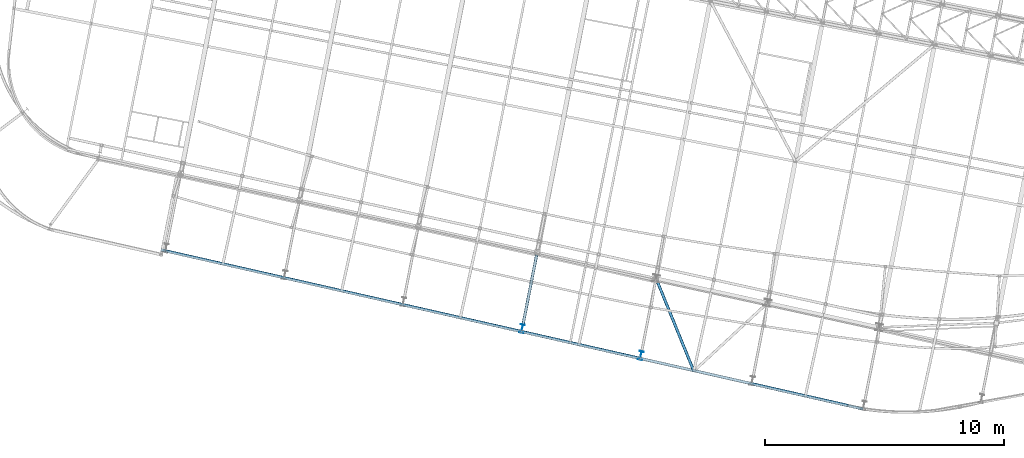
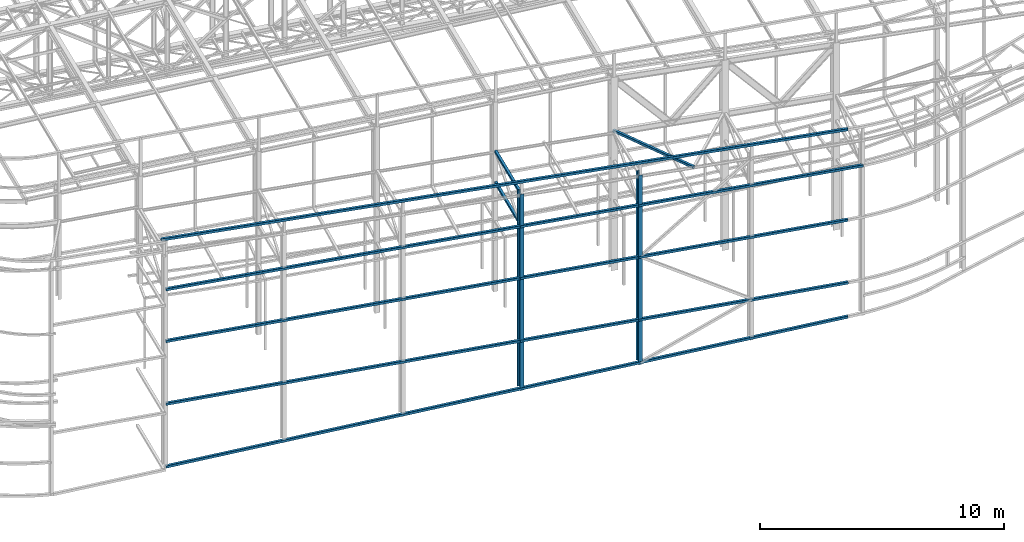
# One storey, part 27 of 215: 10 beams, 10 elements without a shape of their own.
"""IFC2X3 building model written with IfcOpenShell, lengths in millimetres."""

from ifc_helpers import new_model, si_unit, frame, origin_with_axes, origin_2d_with_axis, place, context, subcontext, project, spatial, hollow_rectangle, i_section, extrude, clip, halfspace, material, type_object, element, aggregate, save


model = new_model("IFC2X3")

# Units and contexts
model_context = context("Model", 3, precision=1e-05, world=origin_with_axes())
body_context = subcontext(model_context, "Body", "Model", "MODEL_VIEW")
ifc_project = project(units=[si_unit("LENGTHUNIT", "METRE", prefix="MILLI"), si_unit("AREAUNIT", "SQUARE_METRE"), si_unit("VOLUMEUNIT", "CUBIC_METRE"), si_unit("MASSUNIT", "GRAM", prefix="KILO"), si_unit("TIMEUNIT", "SECOND"), si_unit("PLANEANGLEUNIT", "RADIAN"), si_unit("SOLIDANGLEUNIT", "STERADIAN"), si_unit("THERMODYNAMICTEMPERATUREUNIT", "DEGREE_CELSIUS"), si_unit("LUMINOUSINTENSITYUNIT", "LUMEN")], contexts=[model_context])

# Site, building, storey
site_placement = place(None, origin_with_axes())
site = spatial("IfcSite", under=ifc_project, at=site_placement, CompositionType="ELEMENT")
building_placement = place(site_placement, origin_with_axes())
building = spatial("IfcBuilding", under=site, at=building_placement, Name="Undefined", CompositionType="ELEMENT")
storey_placement = place(building_placement, origin_with_axes())
storey = spatial("IfcBuildingStorey", under=building, at=storey_placement, Name="Undefined", CompositionType="ELEMENT", Elevation=0.0)

# Assembly, beam
assembly_1_placement = place(storey_placement, origin_with_axes())
assembly_1 = element("IfcElementAssembly", 1, at=assembly_1_placement, inside=storey, Name="Steel Assembly", AssemblyPlace="NOTDEFINED", PredefinedType="RIGID_FRAME")
ifc_material = material(Name="STEEL/S275JR")
beam_type_1 = type_object("IfcBeamType", PredefinedType="NOTDEFINED")
beam_1_placement = place(assembly_1_placement, frame((72949.1255548066, 509.827935139979, 10650.1393730401), z_axis=(0.0194175550049472, -0.00439917700112107, 0.999801783254732), x_axis=(-0.975090257036371, 0.22091309700824, 0.0199096510007426)))
beam_1 = element("IfcBeam", 2, at=beam_1_placement, type_object=beam_type_1, material=ifc_material, Name="LISSE", context=body_context, shape_type="SweptSolid", body=[
    extrude(hollow_rectangle(XDim=120.0, YDim=120.0, WallThickness=4.0, InnerFilletRadius=4.0, OuterFilletRadius=8.0, at=origin_2d_with_axis()), frame((29461.0560149092, 3.76084683702483e-12, 1.81898940354586e-12), z_axis=(-1.0, 0.0, 0.0), x_axis=(-6.93889390390723e-18, -1.0, -3.46944695195361e-18)), (0.0, 0.0, 1.0), 29461.1),
])
aggregate(assembly_1, [beam_1])

assembly_2_placement = place(storey_placement, origin_with_axes())
assembly_2 = element("IfcElementAssembly", 3, at=assembly_2_placement, inside=storey, Name="Steel Assembly", AssemblyPlace="NOTDEFINED", PredefinedType="RIGID_FRAME")
beam_type_2 = type_object("IfcBeamType", PredefinedType="NOTDEFINED")
beam_2_placement = place(assembly_2_placement, frame((44418.1952384561, 6974.22611067244, 2980.9622244853), z_axis=(0.220975588983775, 0.975279338928384, -1.1518999999289e-05), x_axis=(0.975279338993088, -0.220975588998434, 0.0)))
beam_2 = element("IfcBeam", 4, at=beam_2_placement, type_object=beam_type_2, material=ifc_material, Name="LISSE", context=body_context, shape_type="SweptSolid", body=[
    extrude(hollow_rectangle(XDim=120.0, YDim=120.0, WallThickness=5.0, InnerFilletRadius=5.0, OuterFilletRadius=10.0, at=origin_2d_with_axis()), frame((29258.826416603, 4.54759742481451e-13, 3.63797880709171e-12), z_axis=(-1.0, 0.0, 0.0), x_axis=(-6.93889390390723e-18, -1.0, -3.46944695195361e-18)), (0.0, 0.0, 1.0), 29258.8),
])
aggregate(assembly_2, [beam_2])

assembly_3_placement = place(storey_placement, origin_with_axes())
assembly_3 = element("IfcElementAssembly", 5, at=assembly_3_placement, inside=storey, Name="Steel Assembly", AssemblyPlace="NOTDEFINED", PredefinedType="RIGID_FRAME")
beam_3_placement = place(assembly_3_placement, frame((44416.3985886134, 6974.67105643174, -155.670493262422), z_axis=(0.221097669099213, 0.975251670437612, -5.24800000234946e-06), x_axis=(0.974081564682385, -0.220832132927994, 0.0489721799840319)))
beam_3 = element("IfcBeam", 6, at=beam_3_placement, type_object=beam_type_2, material=ifc_material, Name="LISSE", context=body_context, shape_type="SweptSolid", body=[
    extrude(hollow_rectangle(XDim=120.0, YDim=120.0, WallThickness=5.0, InnerFilletRadius=5.0, OuterFilletRadius=10.0, at=origin_2d_with_axis()), frame((29289.8930820894, -2.03239460553405e-13, 4.06836788812386e-12), z_axis=(-1.0, 0.0, 0.0), x_axis=(-6.93889390390723e-18, -1.0, -3.46944695195361e-18)), (0.0, 0.0, 1.0), 29289.9),
])
aggregate(assembly_3, [beam_3])

assembly_4_placement = place(storey_placement, origin_with_axes())
assembly_4 = element("IfcElementAssembly", 7, at=assembly_4_placement, inside=storey, Name="Steel Assembly", AssemblyPlace="NOTDEFINED", PredefinedType="RIGID_FRAME")
beam_4_placement = place(assembly_4_placement, frame((44414.7050663599, 6975.05394820363, 8706.00054876969), z_axis=(0.220975588983775, 0.975279338928384, -1.1518999999289e-05), x_axis=(0.975279338993088, -0.220975588998434, 0.0)))
beam_4 = element("IfcBeam", 8, at=beam_4_placement, type_object=beam_type_2, material=ifc_material, Name="LISSE", context=body_context, shape_type="SweptSolid", body=[
    extrude(hollow_rectangle(XDim=120.0, YDim=120.0, WallThickness=5.0, InnerFilletRadius=5.0, OuterFilletRadius=10.0, at=origin_2d_with_axis()), frame((29913.2202389001, 3.63797880709171e-12, 0.0), z_axis=(-1.0, 0.0, 0.0), x_axis=(-6.93889390390723e-18, -1.0, -3.46944695195361e-18)), (0.0, 0.0, 1.0), 29913.2),
])
aggregate(assembly_4, [beam_4])

assembly_5_placement = place(storey_placement, origin_with_axes())
assembly_5 = element("IfcElementAssembly", 9, at=assembly_5_placement, inside=storey, Name="Steel Assembly", AssemblyPlace="NOTDEFINED", PredefinedType="RIGID_FRAME")
beam_5_placement = place(assembly_5_placement, frame((44414.7321978085, 6975.04780065037, 6117.50421482941), z_axis=(0.220975588983775, 0.975279338928384, -1.1518999999289e-05), x_axis=(0.975279338993088, -0.220975588998434, 0.0)))
beam_5 = element("IfcBeam", 10, at=beam_5_placement, type_object=beam_type_2, material=ifc_material, Name="LISSE", context=body_context, shape_type="SweptSolid", body=[
    extrude(hollow_rectangle(XDim=120.0, YDim=120.0, WallThickness=5.0, InnerFilletRadius=5.0, OuterFilletRadius=10.0, at=origin_2d_with_axis()), frame((29258.826416603, 4.54759742481451e-13, 3.63797880709171e-12), z_axis=(-1.0, 0.0, 0.0), x_axis=(-6.93889390390723e-18, -1.0, -3.46944695195361e-18)), (0.0, 0.0, 1.0), 29258.8),
])
aggregate(assembly_5, [beam_5])

assembly_6_placement = place(storey_placement, origin_with_axes())
assembly_6 = element("IfcElementAssembly", 11, at=assembly_6_placement, inside=storey, Name="Steel Assembly", AssemblyPlace="NOTDEFINED", PredefinedType="RIGID_FRAME")
beam_6_placement = place(assembly_6_placement, frame((59367.0999275982, 3897.55622107733, 10272.058803346), z_axis=(-0.981422412140383, 0.191859451027444, 0.0), x_axis=(0.191859470081235, 0.981422408415534, 0.0)))
beam_6 = element("IfcBeam", 12, at=beam_6_placement, type_object=beam_type_2, material=ifc_material, context=body_context, shape_type="SweptSolid", body=[
    extrude(hollow_rectangle(XDim=120.0, YDim=120.0, WallThickness=5.0, InnerFilletRadius=5.0, OuterFilletRadius=10.0, at=origin_2d_with_axis()), frame((2966.85565612287, 1.81898940293233e-12, 8.23467865041747e-14), z_axis=(-1.0, 0.0, 0.0), x_axis=(-6.93889390390723e-18, -1.0, -3.46944695195361e-18)), (0.0, 0.0, 1.0), 2966.9),
])
aggregate(assembly_6, [beam_6])

assembly_7_placement = place(storey_placement, origin_with_axes())
assembly_7 = element("IfcElementAssembly", 13, at=assembly_7_placement, inside=storey, Name="Steel Assembly", AssemblyPlace="NOTDEFINED", PredefinedType="RIGID_FRAME")
beam_7_placement = place(assembly_7_placement, frame((64928.9235682243, 5825.83831604516, 10170.9442700943), z_axis=(0.9261593075418, 0.377132519220623, 0.0), x_axis=(0.377110851872509, -0.926106097686905, -0.0107191989963761)))
beam_7 = element("IfcBeam", 14, at=beam_7_placement, type_object=beam_type_2, material=ifc_material, context=body_context, shape_type="SweptSolid", body=[
    extrude(hollow_rectangle(XDim=120.0, YDim=120.0, WallThickness=5.0, InnerFilletRadius=5.0, OuterFilletRadius=10.0, at=origin_2d_with_axis()), frame((4187.14765799913, 1.81172586020614e-12, 1.01987367649014e-13), z_axis=(-1.0, 0.0, 0.0), x_axis=(-6.93889390390723e-18, -1.0, -3.46944695195361e-18)), (0.0, 0.0, 1.0), 4187.1),
])
aggregate(assembly_7, [beam_7])

assembly_8_placement = place(storey_placement, origin_with_axes())
assembly_8 = element("IfcElementAssembly", 15, at=assembly_8_placement, inside=storey, Name="Steel Assembly", AssemblyPlace="NOTDEFINED", PredefinedType="RIGID_FRAME")
beam_8_placement = place(assembly_8_placement, frame((59936.3188722574, 6809.29492326561, 8710.00002361416), z_axis=(0.0, 0.0, 1.0), x_axis=(-0.191859508000518, -0.981422401002646, -1.00000033853845e-09)))
beam_8 = element("IfcBeam", 16, at=beam_8_placement, type_object=beam_type_2, material=ifc_material, Name="POUTRE", context=body_context, shape_type="SweptSolid", body=[
    extrude(hollow_rectangle(XDim=120.0, YDim=120.0, WallThickness=5.0, InnerFilletRadius=5.0, OuterFilletRadius=10.0, at=origin_2d_with_axis()), frame((2966.85565612287, 1.81898940293233e-12, 8.23467865041747e-14), z_axis=(-1.0, 0.0, 0.0), x_axis=(-6.93889390390723e-18, -1.0, -3.46944695195361e-18)), (0.0, 0.0, 1.0), 2966.9),
])
aggregate(assembly_8, [beam_8])

assembly_9_placement = place(storey_placement, origin_with_axes())
assembly_9 = element("IfcElementAssembly", 17, at=assembly_9_placement, inside=storey, Name="Steel Assembly", AssemblyPlace="NOTDEFINED", PredefinedType="RIGID_FRAME")
beam_type_3 = type_object("IfcBeamType", Name="IPE360", PredefinedType="NOTDEFINED")
beam_9_placement = place(assembly_9_placement, frame((64290.1332308091, 2597.44989684864, 10230.9408261733), z_axis=(0.191859470081235, 0.981422408415534, 0.0), x_axis=(0.0, 0.0, -1.0)))
beam_9 = element("IfcBeam", 18, at=beam_9_placement, type_object=beam_type_3, material=ifc_material, Name="MONTANT", ObjectType="IPE360", context=body_context, shape_type="Clipping", body=[
    clip(extrude(i_section(OverallWidth=170.0, OverallDepth=360.0, WebThickness=8.0, FlangeThickness=12.69999981, FilletRadius=18.0, at=origin_2d_with_axis()), frame((9474.69776530194, 0.0, 1.81898940354586e-12), z_axis=(-1.0, 0.0, 0.0), x_axis=(-6.93889390390723e-18, -1.0, -3.46944695195361e-18)), (0.0, 0.0, 1.0), 9474.7), halfspace(frame((9475.99104055322, 136.907168000318, -628.253239155089), z_axis=(-0.998850991769565, 0.0479026806605242, 0.0014245794090564), x_axis=(-1.0230287445127e-09, -0.0297259118404429, 0.999558087439271)), True)),
])
aggregate(assembly_9, [beam_9])

assembly_10_placement = place(storey_placement, origin_with_axes())
assembly_10 = element("IfcElementAssembly", 19, at=assembly_10_placement, inside=storey, Name="Steel Assembly", AssemblyPlace="NOTDEFINED", PredefinedType="RIGID_FRAME")
beam_10_placement = place(assembly_10_placement, frame((59326.7286192196, 3722.04119425557, 10327.0588025701), z_axis=(0.191859470081235, 0.981422408415534, 0.0), x_axis=(0.0, 0.0, -1.0)))
beam_10 = element("IfcBeam", 20, at=beam_10_placement, type_object=beam_type_3, material=ifc_material, Name="MONTANT", ObjectType="IPE360", context=body_context, shape_type="Clipping", body=[
    clip(extrude(i_section(OverallWidth=170.0, OverallDepth=360.0, WebThickness=8.0, FlangeThickness=12.69999981, FilletRadius=18.0, at=origin_2d_with_axis()), frame((9814.99103672964, 0.0, 0.0), z_axis=(-1.0, 0.0, 0.0), x_axis=(-6.93889390390723e-18, -1.0, -3.46944695195361e-18)), (0.0, 0.0, 1.0), 9815.0), halfspace(frame((9816.28420208296, 136.90908707885, -628.394825286985), z_axis=(-0.998850991769565, 0.0479026806605242, 0.0014245794090564), x_axis=(-1.0230287445127e-09, -0.0297259118404429, 0.999558087439271)), True)),
])
aggregate(assembly_10, [beam_10])

save(model, "model.ifc")
